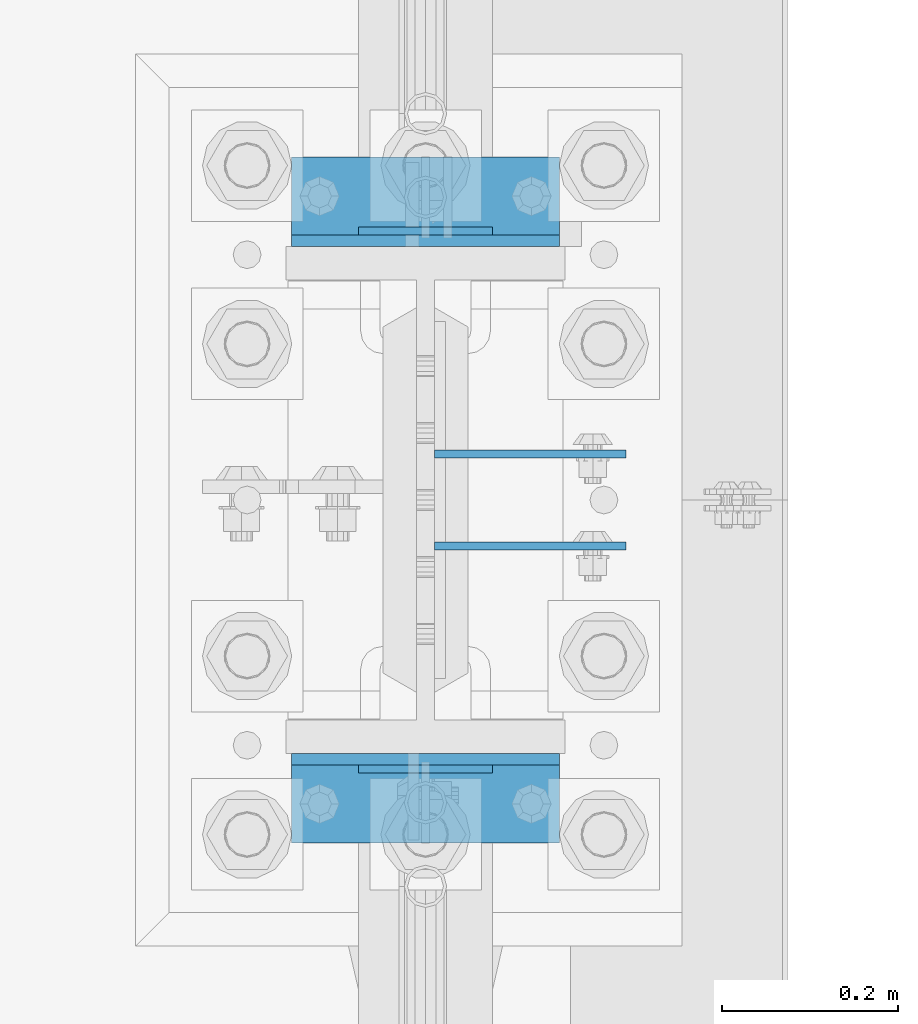
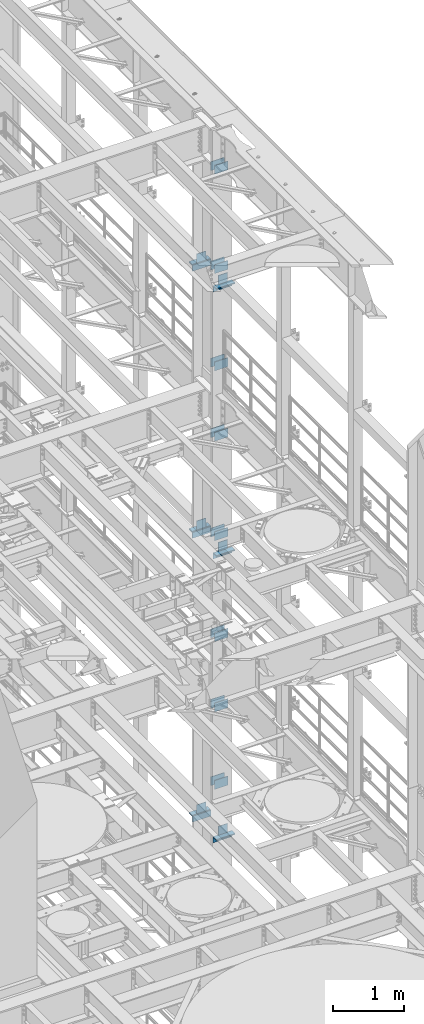
# One storey, part 1338 of 1876: 34 beams, 8 elements without a shape of their own.
"""IFC2X3 building model written with IfcOpenShell, lengths in millimetres."""

from ifc_helpers import new_model, si_unit, frame, origin_with_axes, place, context, subcontext, project, spatial, faceted_brep, material, type_object, element, aggregate, save


model = new_model("IFC2X3")

# Units and contexts
model_context = context("Model", 3, precision=1e-05, world=origin_with_axes())
body_context = subcontext(model_context, "Body", "Model", "MODEL_VIEW")
ifc_project = project(units=[si_unit("LENGTHUNIT", "METRE", prefix="MILLI"), si_unit("AREAUNIT", "SQUARE_METRE"), si_unit("VOLUMEUNIT", "CUBIC_METRE"), si_unit("MASSUNIT", "GRAM", prefix="KILO"), si_unit("TIMEUNIT", "SECOND"), si_unit("PLANEANGLEUNIT", "RADIAN"), si_unit("SOLIDANGLEUNIT", "STERADIAN"), si_unit("THERMODYNAMICTEMPERATUREUNIT", "DEGREE_CELSIUS"), si_unit("LUMINOUSINTENSITYUNIT", "LUMEN")], contexts=[model_context])

# Site, building, storey
site_placement = place(None, origin_with_axes())
site = spatial("IfcSite", under=ifc_project, at=site_placement, CompositionType="ELEMENT")
building_placement = place(site_placement, origin_with_axes())
building = spatial("IfcBuilding", under=site, at=building_placement, Name="Undefined", CompositionType="ELEMENT")
storey_placement = place(building_placement, origin_with_axes())
storey = spatial("IfcBuildingStorey", under=building, at=storey_placement, Name="Undefined", CompositionType="ELEMENT", Elevation=0.0)

# Assembly, beams
assembly_1_placement = place(storey_placement, origin_with_axes())
assembly_1 = element("IfcElementAssembly", 1, at=assembly_1_placement, inside=storey, Name="COLUMN", AssemblyPlace="NOTDEFINED", PredefinedType="RIGID_FRAME")
ifc_material = material(Name="STEEL/A36")
beam_type_1 = type_object("IfcBeamType", PredefinedType="NOTDEFINED")
beam_1_placement = place(assembly_1_placement, frame((7630.31875, 7672.38750076294, 21678.9), z_axis=(0.0, 0.0, -1.0), x_axis=(1.0, 0.0, 0.0)))
beam_1 = element("IfcBeam", 2, at=beam_1_placement, type_object=beam_type_1, material=ifc_material, Name="PLATE", context=body_context, shape_type="Brep", body=[
    faceted_brep([(0.0, 4.76249999999982, -76.1999999999998), (3.63797880709171e-12, 4.76249999999982, 76.1999969482422), (218.28125, 4.76250000000005, 76.2000000000007), (218.28125, 4.76250000000005, -76.2000000000007), (3.63797880709171e-12, -4.76249999999982, 76.1999969482422), (218.28125, -4.76250000000005, 76.2000000000007), (0.0, -4.76249999999982, -76.1999999999998), (218.28125, -4.76250000000005, -76.2000000000007)], [[[0, 1, 2, 3]], [[1, 4, 5, 2]], [[4, 6, 7, 5]], [[6, 0, 3, 7]], [[5, 7, 3, 2]], [[6, 4, 1, 0]]]),
])
beam_2_placement = place(assembly_1_placement, frame((7630.31875, 7567.61250076294, 21678.9), z_axis=(0.0, 0.0, -1.0), x_axis=(1.0, 0.0, 0.0)))
beam_2 = element("IfcBeam", 3, at=beam_2_placement, type_object=beam_type_1, material=ifc_material, Name="PLATE", context=body_context, shape_type="Brep", body=[
    faceted_brep([(0.0, 4.76249999999982, -76.1999999999998), (3.63797880709171e-12, 4.76249999999982, 76.1999969482422), (218.28125, 4.76250000000005, 76.2000000000007), (218.28125, 4.76250000000005, -76.2000000000007), (3.63797880709171e-12, -4.76249999999982, 76.1999969482422), (218.28125, -4.76250000000005, 76.2000000000007), (0.0, -4.76249999999982, -76.1999999999998), (218.28125, -4.76250000000005, -76.2000000000007)], [[[0, 1, 2, 3]], [[1, 4, 5, 2]], [[4, 6, 7, 5]], [[6, 0, 3, 7]], [[5, 7, 3, 2]], [[6, 4, 1, 0]]]),
])
beam_3_placement = place(assembly_1_placement, frame((7630.31875, 7672.38750076294, 19958.05), z_axis=(0.0, 0.0, -1.0), x_axis=(1.0, 0.0, 0.0)))
beam_3 = element("IfcBeam", 4, at=beam_3_placement, type_object=beam_type_1, material=ifc_material, Name="PLATE", context=body_context, shape_type="Brep", body=[
    faceted_brep([(0.0, 4.76249999999982, -76.1999999999998), (3.63797880709171e-12, 4.76249999999982, 76.1999969482422), (218.28125, 4.76250000000005, 76.2000000000007), (218.28125, 4.76250000000005, -76.2000000000007), (3.63797880709171e-12, -4.76249999999982, 76.1999969482422), (218.28125, -4.76250000000005, 76.2000000000007), (0.0, -4.76249999999982, -76.1999999999998), (218.28125, -4.76250000000005, -76.2000000000007)], [[[0, 1, 2, 3]], [[1, 4, 5, 2]], [[4, 6, 7, 5]], [[6, 0, 3, 7]], [[5, 7, 3, 2]], [[6, 4, 1, 0]]]),
])
beam_4_placement = place(assembly_1_placement, frame((7630.31875, 7567.61250076294, 19958.05), z_axis=(0.0, 0.0, -1.0), x_axis=(1.0, 0.0, 0.0)))
beam_4 = element("IfcBeam", 5, at=beam_4_placement, type_object=beam_type_1, material=ifc_material, Name="PLATE", context=body_context, shape_type="Brep", body=[
    faceted_brep([(0.0, 4.76249999999982, -76.1999999999998), (3.63797880709171e-12, 4.76249999999982, 76.1999969482422), (218.28125, 4.76250000000005, 76.2000000000007), (218.28125, 4.76250000000005, -76.2000000000007), (3.63797880709171e-12, -4.76249999999982, 76.1999969482422), (218.28125, -4.76250000000005, 76.2000000000007), (0.0, -4.76249999999982, -76.1999999999998), (218.28125, -4.76250000000005, -76.2000000000007)], [[[0, 1, 2, 3]], [[1, 4, 5, 2]], [[4, 6, 7, 5]], [[6, 0, 3, 7]], [[5, 7, 3, 2]], [[6, 4, 1, 0]]]),
])
beam_5_placement = place(assembly_1_placement, frame((7630.31875, 7672.38750076294, 18275.3), z_axis=(0.0, 0.0, -1.0), x_axis=(1.0, 0.0, 0.0)))
beam_5 = element("IfcBeam", 6, at=beam_5_placement, type_object=beam_type_1, material=ifc_material, Name="PLATE", context=body_context, shape_type="Brep", body=[
    faceted_brep([(0.0, 4.76249999999982, -76.1999999999998), (3.63797880709171e-12, 4.76249999999982, 76.1999969482422), (218.28125, 4.76250000000005, 76.2000000000007), (218.28125, 4.76250000000005, -76.2000000000007), (3.63797880709171e-12, -4.76249999999982, 76.1999969482422), (218.28125, -4.76250000000005, 76.2000000000007), (0.0, -4.76249999999982, -76.1999999999998), (218.28125, -4.76250000000005, -76.2000000000007)], [[[0, 1, 2, 3]], [[1, 4, 5, 2]], [[4, 6, 7, 5]], [[6, 0, 3, 7]], [[5, 7, 3, 2]], [[6, 4, 1, 0]]]),
])
beam_6_placement = place(assembly_1_placement, frame((7630.31875, 7567.61250076294, 18275.3), z_axis=(0.0, 0.0, -1.0), x_axis=(1.0, 0.0, 0.0)))
beam_6 = element("IfcBeam", 7, at=beam_6_placement, type_object=beam_type_1, material=ifc_material, Name="PLATE", context=body_context, shape_type="Brep", body=[
    faceted_brep([(0.0, 4.76249999999982, -76.1999999999998), (3.63797880709171e-12, 4.76249999999982, 76.1999969482422), (218.28125, 4.76250000000005, 76.2000000000007), (218.28125, 4.76250000000005, -76.2000000000007), (3.63797880709171e-12, -4.76249999999982, 76.1999969482422), (218.28125, -4.76250000000005, 76.2000000000007), (0.0, -4.76249999999982, -76.1999999999998), (218.28125, -4.76250000000005, -76.2000000000007)], [[[0, 1, 2, 3]], [[1, 4, 5, 2]], [[4, 6, 7, 5]], [[6, 0, 3, 7]], [[5, 7, 3, 2]], [[6, 4, 1, 0]]]),
])
beam_7_placement = place(assembly_1_placement, frame((7630.31875, 7672.38750076294, 17056.1), z_axis=(0.0, 0.0, -1.0), x_axis=(1.0, 0.0, 0.0)))
beam_7 = element("IfcBeam", 8, at=beam_7_placement, type_object=beam_type_1, material=ifc_material, Name="PLATE", context=body_context, shape_type="Brep", body=[
    faceted_brep([(0.0, 4.76249999999982, -76.1999999999998), (3.63797880709171e-12, 4.76249999999982, 76.1999969482422), (218.28125, 4.76250000000005, 76.2000000000007), (218.28125, 4.76250000000005, -76.2000000000007), (3.63797880709171e-12, -4.76249999999982, 76.1999969482422), (218.28125, -4.76250000000005, 76.2000000000007), (0.0, -4.76249999999982, -76.1999999999998), (218.28125, -4.76250000000005, -76.2000000000007)], [[[0, 1, 2, 3]], [[1, 4, 5, 2]], [[4, 6, 7, 5]], [[6, 0, 3, 7]], [[5, 7, 3, 2]], [[6, 4, 1, 0]]]),
])
beam_8_placement = place(assembly_1_placement, frame((7630.31875, 7567.61250076294, 17056.1), z_axis=(0.0, 0.0, -1.0), x_axis=(1.0, 0.0, 0.0)))
beam_8 = element("IfcBeam", 9, at=beam_8_placement, type_object=beam_type_1, material=ifc_material, Name="PLATE", context=body_context, shape_type="Brep", body=[
    faceted_brep([(0.0, 4.76249999999982, -76.1999999999998), (3.63797880709171e-12, 4.76249999999982, 76.1999969482422), (218.28125, 4.76250000000005, 76.2000000000007), (218.28125, 4.76250000000005, -76.2000000000007), (3.63797880709171e-12, -4.76249999999982, 76.1999969482422), (218.28125, -4.76250000000005, 76.2000000000007), (0.0, -4.76249999999982, -76.1999999999998), (218.28125, -4.76250000000005, -76.2000000000007)], [[[0, 1, 2, 3]], [[1, 4, 5, 2]], [[4, 6, 7, 5]], [[6, 0, 3, 7]], [[5, 7, 3, 2]], [[6, 4, 1, 0]]]),
])
beam_9_placement = place(assembly_1_placement, frame((7630.31875, 7672.38750076294, 15335.25), z_axis=(0.0, 0.0, -1.0), x_axis=(1.0, 0.0, 0.0)))
beam_9 = element("IfcBeam", 10, at=beam_9_placement, type_object=beam_type_1, material=ifc_material, Name="PLATE", context=body_context, shape_type="Brep", body=[
    faceted_brep([(0.0, 4.76249999999982, -76.1999999999998), (3.63797880709171e-12, 4.76249999999982, 76.1999969482422), (218.28125, 4.76250000000005, 76.2000000000007), (218.28125, 4.76250000000005, -76.2000000000007), (3.63797880709171e-12, -4.76249999999982, 76.1999969482422), (218.28125, -4.76250000000005, 76.2000000000007), (0.0, -4.76249999999982, -76.1999999999998), (218.28125, -4.76250000000005, -76.2000000000007)], [[[0, 1, 2, 3]], [[1, 4, 5, 2]], [[4, 6, 7, 5]], [[6, 0, 3, 7]], [[5, 7, 3, 2]], [[6, 4, 1, 0]]]),
])
beam_10_placement = place(assembly_1_placement, frame((7630.31875, 7567.61250076294, 15335.25), z_axis=(0.0, 0.0, -1.0), x_axis=(1.0, 0.0, 0.0)))
beam_10 = element("IfcBeam", 11, at=beam_10_placement, type_object=beam_type_1, material=ifc_material, Name="PLATE", context=body_context, shape_type="Brep", body=[
    faceted_brep([(0.0, 4.76249999999982, -76.1999999999998), (3.63797880709171e-12, 4.76249999999982, 76.1999969482422), (218.28125, 4.76250000000005, 76.2000000000007), (218.28125, 4.76250000000005, -76.2000000000007), (3.63797880709171e-12, -4.76249999999982, 76.1999969482422), (218.28125, -4.76250000000005, 76.2000000000007), (0.0, -4.76249999999982, -76.1999999999998), (218.28125, -4.76250000000005, -76.2000000000007)], [[[0, 1, 2, 3]], [[1, 4, 5, 2]], [[4, 6, 7, 5]], [[6, 0, 3, 7]], [[5, 7, 3, 2]], [[6, 4, 1, 0]]]),
])

assembly_2_placement = place(storey_placement, origin_with_axes())
assembly_2 = element("IfcElementAssembly", 12, at=assembly_2_placement, inside=storey, Name="COLUMN", AssemblyPlace="NOTDEFINED", PredefinedType="RIGID_FRAME")
beam_11_placement = place(assembly_2_placement, frame((7630.31875, 7672.38750076294, 13589.0), z_axis=(0.0, 0.0, -1.0), x_axis=(1.0, 0.0, 0.0)))
beam_11 = element("IfcBeam", 13, at=beam_11_placement, type_object=beam_type_1, material=ifc_material, Name="PLATE", context=body_context, shape_type="Brep", body=[
    faceted_brep([(0.0, 4.76249999999982, -76.1999999999998), (3.63797880709171e-12, 4.76249999999982, 76.1999969482422), (218.28125, 4.76250000000005, 76.2000000000007), (218.28125, 4.76250000000005, -76.2000000000007), (3.63797880709171e-12, -4.76249999999982, 76.1999969482422), (218.28125, -4.76250000000005, 76.2000000000007), (0.0, -4.76249999999982, -76.1999999999998), (218.28125, -4.76250000000005, -76.2000000000007)], [[[0, 1, 2, 3]], [[1, 4, 5, 2]], [[4, 6, 7, 5]], [[6, 0, 3, 7]], [[5, 7, 3, 2]], [[6, 4, 1, 0]]]),
])
beam_12_placement = place(assembly_2_placement, frame((7630.31875, 7567.61250076294, 13589.0), z_axis=(0.0, 0.0, -1.0), x_axis=(1.0, 0.0, 0.0)))
beam_12 = element("IfcBeam", 14, at=beam_12_placement, type_object=beam_type_1, material=ifc_material, Name="PLATE", context=body_context, shape_type="Brep", body=[
    faceted_brep([(0.0, 4.76249999999982, -76.1999999999998), (3.63797880709171e-12, 4.76249999999982, 76.1999969482422), (218.28125, 4.76250000000005, 76.2000000000007), (218.28125, 4.76250000000005, -76.2000000000007), (3.63797880709171e-12, -4.76249999999982, 76.1999969482422), (218.28125, -4.76250000000005, 76.2000000000007), (0.0, -4.76249999999982, -76.1999999999998), (218.28125, -4.76250000000005, -76.2000000000007)], [[[0, 1, 2, 3]], [[1, 4, 5, 2]], [[4, 6, 7, 5]], [[6, 0, 3, 7]], [[5, 7, 3, 2]], [[6, 4, 1, 0]]]),
])
beam_13_placement = place(assembly_2_placement, frame((7630.31875, 7672.38750076294, 12369.8), z_axis=(0.0, 0.0, -1.0), x_axis=(1.0, 0.0, 0.0)))
beam_13 = element("IfcBeam", 15, at=beam_13_placement, type_object=beam_type_1, material=ifc_material, Name="PLATE", context=body_context, shape_type="Brep", body=[
    faceted_brep([(0.0, 4.76249999999982, -76.1999999999998), (3.63797880709171e-12, 4.76249999999982, 76.1999969482422), (218.28125, 4.76250000000005, 76.2000000000007), (218.28125, 4.76250000000005, -76.2000000000007), (3.63797880709171e-12, -4.76249999999982, 76.1999969482422), (218.28125, -4.76250000000005, 76.2000000000007), (0.0, -4.76249999999982, -76.1999999999998), (218.28125, -4.76250000000005, -76.2000000000007)], [[[0, 1, 2, 3]], [[1, 4, 5, 2]], [[4, 6, 7, 5]], [[6, 0, 3, 7]], [[5, 7, 3, 2]], [[6, 4, 1, 0]]]),
])
beam_14_placement = place(assembly_2_placement, frame((7630.31875, 7567.61250076294, 12369.8), z_axis=(0.0, 0.0, -1.0), x_axis=(1.0, 0.0, 0.0)))
beam_14 = element("IfcBeam", 16, at=beam_14_placement, type_object=beam_type_1, material=ifc_material, Name="PLATE", context=body_context, shape_type="Brep", body=[
    faceted_brep([(0.0, 4.76249999999982, -76.1999999999998), (3.63797880709171e-12, 4.76249999999982, 76.1999969482422), (218.28125, 4.76250000000005, 76.2000000000007), (218.28125, 4.76250000000005, -76.2000000000007), (3.63797880709171e-12, -4.76249999999982, 76.1999969482422), (218.28125, -4.76250000000005, 76.2000000000007), (0.0, -4.76249999999982, -76.1999999999998), (218.28125, -4.76250000000005, -76.2000000000007)], [[[0, 1, 2, 3]], [[1, 4, 5, 2]], [[4, 6, 7, 5]], [[6, 0, 3, 7]], [[5, 7, 3, 2]], [[6, 4, 1, 0]]]),
])
beam_15_placement = place(assembly_2_placement, frame((7630.31875, 7672.38750076294, 11029.95), z_axis=(0.0, 0.0, -1.0), x_axis=(1.0, 0.0, 0.0)))
beam_15 = element("IfcBeam", 17, at=beam_15_placement, type_object=beam_type_1, material=ifc_material, Name="PLATE", context=body_context, shape_type="Brep", body=[
    faceted_brep([(0.0, 4.76249999999982, -76.1999999999998), (3.63797880709171e-12, 4.76249999999982, 76.1999969482422), (218.28125, 4.76250000000005, 76.2000000000007), (218.28125, 4.76250000000005, -76.2000000000007), (3.63797880709171e-12, -4.76249999999982, 76.1999969482422), (218.28125, -4.76250000000005, 76.2000000000007), (0.0, -4.76249999999982, -76.1999999999998), (218.28125, -4.76250000000005, -76.2000000000007)], [[[0, 1, 2, 3]], [[1, 4, 5, 2]], [[4, 6, 7, 5]], [[6, 0, 3, 7]], [[5, 7, 3, 2]], [[6, 4, 1, 0]]]),
])
beam_16_placement = place(assembly_2_placement, frame((7630.31875, 7567.61250076294, 11029.95), z_axis=(0.0, 0.0, -1.0), x_axis=(1.0, 0.0, 0.0)))
beam_16 = element("IfcBeam", 18, at=beam_16_placement, type_object=beam_type_1, material=ifc_material, Name="PLATE", context=body_context, shape_type="Brep", body=[
    faceted_brep([(0.0, 4.76249999999982, -76.1999999999998), (3.63797880709171e-12, 4.76249999999982, 76.1999969482422), (218.28125, 4.76250000000005, 76.2000000000007), (218.28125, 4.76250000000005, -76.2000000000007), (3.63797880709171e-12, -4.76249999999982, 76.1999969482422), (218.28125, -4.76250000000005, 76.2000000000007), (0.0, -4.76249999999982, -76.1999999999998), (218.28125, -4.76250000000005, -76.2000000000007)], [[[0, 1, 2, 3]], [[1, 4, 5, 2]], [[4, 6, 7, 5]], [[6, 0, 3, 7]], [[5, 7, 3, 2]], [[6, 4, 1, 0]]]),
])

# Assembly, beam
assembly_3_placement = place(storey_placement, origin_with_axes())
assembly_3 = element("IfcElementAssembly", 19, at=assembly_3_placement, inside=storey, Name="BEAM", AssemblyPlace="NOTDEFINED", PredefinedType="RIGID_FRAME")
beam_17_placement = place(assembly_3_placement, frame((7696.2, 7926.3875, 19958.05), z_axis=(0.0, 0.0, 1.0), x_axis=(-1.0, 0.0, 0.0)))
beam_17 = element("IfcBeam", 20, at=beam_17_placement, type_object=beam_type_1, material=ifc_material, Name="PLATE", context=body_context, shape_type="Brep", body=[
    faceted_brep([(0.0, 4.76249999999982, -76.1999999999998), (3.63797880709171e-12, 4.76249999999982, 76.1999969482422), (152.399993896484, 4.76250000000073, 76.1999969482422), (152.4, 4.76249999999982, -76.1999999999998), (3.63797880709171e-12, -4.76249999999982, 76.1999969482422), (152.399993896484, -4.76250000000073, 76.1999969482422), (0.0, -4.76249999999982, -76.1999999999998), (152.4, -4.76249999999982, -76.1999999999998)], [[[0, 1, 2, 3]], [[4, 5, 2, 1]], [[4, 6, 7, 5]], [[6, 0, 3, 7]], [[5, 7, 3, 2]], [[6, 4, 1, 0]]]),
])

assembly_4_placement = place(storey_placement, origin_with_axes())
assembly_4 = element("IfcElementAssembly", 21, at=assembly_4_placement, inside=storey, Name="BEAM", AssemblyPlace="NOTDEFINED", PredefinedType="RIGID_FRAME")
beam_18_placement = place(assembly_4_placement, frame((7696.2, 7313.6125, 19958.05), z_axis=(0.0, 0.0, -1.0), x_axis=(-1.0, 0.0, 0.0)))
beam_18 = element("IfcBeam", 22, at=beam_18_placement, type_object=beam_type_1, material=ifc_material, Name="PLATE", context=body_context, shape_type="Brep", body=[
    faceted_brep([(0.0, 4.76249999999982, -76.1999999999998), (3.63797880709171e-12, 4.76249999999982, 76.1999969482422), (152.399993896484, 4.76250000000073, 76.1999969482422), (152.4, 4.76249999999982, -76.1999999999998), (3.63797880709171e-12, -4.76249999999982, 76.1999969482422), (152.399993896484, -4.76250000000073, 76.1999969482422), (0.0, -4.76249999999982, -76.1999999999998), (152.4, -4.76249999999982, -76.1999999999998)], [[[0, 1, 2, 3]], [[4, 5, 2, 1]], [[4, 6, 7, 5]], [[6, 0, 3, 7]], [[5, 7, 3, 2]], [[6, 4, 1, 0]]]),
])

assembly_5_placement = place(storey_placement, origin_with_axes())
assembly_5 = element("IfcElementAssembly", 23, at=assembly_5_placement, inside=storey, Name="BEAM", AssemblyPlace="NOTDEFINED", PredefinedType="RIGID_FRAME")
beam_19_placement = place(assembly_5_placement, frame((7696.2, 7926.3875, 15335.25), z_axis=(0.0, 0.0, 1.0), x_axis=(-1.0, 0.0, 0.0)))
beam_19 = element("IfcBeam", 24, at=beam_19_placement, type_object=beam_type_1, material=ifc_material, Name="PLATE", context=body_context, shape_type="Brep", body=[
    faceted_brep([(0.0, 4.76249999999982, -76.1999999999998), (3.63797880709171e-12, 4.76249999999982, 76.1999969482422), (152.399993896484, 4.76250000000073, 76.1999969482422), (152.4, 4.76249999999982, -76.1999999999998), (3.63797880709171e-12, -4.76249999999982, 76.1999969482422), (152.399993896484, -4.76250000000073, 76.1999969482422), (0.0, -4.76249999999982, -76.1999999999998), (152.4, -4.76249999999982, -76.1999999999998)], [[[0, 1, 2, 3]], [[4, 5, 2, 1]], [[4, 6, 7, 5]], [[6, 0, 3, 7]], [[5, 7, 3, 2]], [[6, 4, 1, 0]]]),
])

assembly_6_placement = place(storey_placement, origin_with_axes())
assembly_6 = element("IfcElementAssembly", 25, at=assembly_6_placement, inside=storey, Name="BEAM", AssemblyPlace="NOTDEFINED", PredefinedType="RIGID_FRAME")
beam_20_placement = place(assembly_6_placement, frame((7696.2, 7313.6125, 15335.25), z_axis=(0.0, 0.0, -1.0), x_axis=(-1.0, 0.0, 0.0)))
beam_20 = element("IfcBeam", 26, at=beam_20_placement, type_object=beam_type_1, material=ifc_material, Name="PLATE", context=body_context, shape_type="Brep", body=[
    faceted_brep([(0.0, 4.76249999999982, -76.1999999999998), (3.63797880709171e-12, 4.76249999999982, 76.1999969482422), (152.399993896484, 4.76250000000073, 76.1999969482422), (152.4, 4.76249999999982, -76.1999999999998), (3.63797880709171e-12, -4.76249999999982, 76.1999969482422), (152.399993896484, -4.76250000000073, 76.1999969482422), (0.0, -4.76249999999982, -76.1999999999998), (152.4, -4.76249999999982, -76.1999999999998)], [[[0, 1, 2, 3]], [[4, 5, 2, 1]], [[4, 6, 7, 5]], [[6, 0, 3, 7]], [[5, 7, 3, 2]], [[6, 4, 1, 0]]]),
])

assembly_7_placement = place(storey_placement, origin_with_axes())
assembly_7 = element("IfcElementAssembly", 27, at=assembly_7_placement, inside=storey, Name="BEAM", AssemblyPlace="NOTDEFINED", PredefinedType="RIGID_FRAME")
beam_21_placement = place(assembly_7_placement, frame((7696.2, 7926.3875, 10420.35), z_axis=(0.0, 0.0, 1.0), x_axis=(-1.0, 0.0, 0.0)))
beam_21 = element("IfcBeam", 28, at=beam_21_placement, type_object=beam_type_1, material=ifc_material, Name="PLATE", context=body_context, shape_type="Brep", body=[
    faceted_brep([(0.0, 4.76249999999982, -76.1999999999998), (3.63797880709171e-12, 4.76249999999982, 76.1999969482422), (152.399993896484, 4.76250000000073, 76.1999969482422), (152.4, 4.76249999999982, -76.1999999999998), (3.63797880709171e-12, -4.76249999999982, 76.1999969482422), (152.399993896484, -4.76250000000073, 76.1999969482422), (0.0, -4.76249999999982, -76.1999999999998), (152.4, -4.76249999999982, -76.1999999999998)], [[[0, 1, 2, 3]], [[4, 5, 2, 1]], [[4, 6, 7, 5]], [[6, 0, 3, 7]], [[5, 7, 3, 2]], [[6, 4, 1, 0]]]),
])

assembly_8_placement = place(storey_placement, origin_with_axes())
assembly_8 = element("IfcElementAssembly", 29, at=assembly_8_placement, inside=storey, Name="BEAM", AssemblyPlace="NOTDEFINED", PredefinedType="RIGID_FRAME")
beam_22_placement = place(assembly_8_placement, frame((7696.2, 7313.6125, 10420.35), z_axis=(0.0, 0.0, -1.0), x_axis=(-1.0, 0.0, 0.0)))
beam_22 = element("IfcBeam", 30, at=beam_22_placement, type_object=beam_type_1, material=ifc_material, Name="PLATE", context=body_context, shape_type="Brep", body=[
    faceted_brep([(0.0, 4.76249999999982, -76.1999999999998), (3.63797880709171e-12, 4.76249999999982, 76.1999969482422), (152.399993896484, 4.76250000000073, 76.1999969482422), (152.4, 4.76249999999982, -76.1999999999998), (3.63797880709171e-12, -4.76249999999982, 76.1999969482422), (152.399993896484, -4.76250000000073, 76.1999969482422), (0.0, -4.76249999999982, -76.1999999999998), (152.4, -4.76249999999982, -76.1999999999998)], [[[0, 1, 2, 3]], [[4, 5, 2, 1]], [[4, 6, 7, 5]], [[6, 0, 3, 7]], [[5, 7, 3, 2]], [[6, 4, 1, 0]]]),
])

# Beam
beam_type_2 = type_object("IfcBeamType", PredefinedType="NOTDEFINED")
beam_23_placement = place(assembly_3_placement, frame((7467.6, 7966.075, 19877.0875), z_axis=(0.0, 1.0, 0.0), x_axis=(1.0, 0.0, 0.0)))
beam_23 = element("IfcBeam", 31, at=beam_23_placement, type_object=beam_type_2, material=ifc_material, Name="PLATE", context=body_context, shape_type="Brep", body=[
    faceted_brep([(0.0, 4.76250000000073, -44.4499999999998), (0.0, 4.76250000000073, 44.4499999999998), (304.799999999999, 4.76250000000073, 44.4499999999998), (304.799999999999, 4.76250000000073, -44.4499999999998), (0.0, -4.76250000000073, 44.4499999999998), (304.799999999999, -4.76250000000073, 44.4499999999998), (0.0, -4.76250000000073, -44.4499999999998), (304.799999999999, -4.76250000000073, -44.4499999999998)], [[[0, 1, 2, 3]], [[1, 4, 5, 2]], [[4, 6, 7, 5]], [[6, 0, 3, 7]], [[5, 7, 3, 2]], [[6, 4, 1, 0]]]),
])

aggregate(assembly_3, [beam_17, beam_23])

beam_24_placement = place(assembly_4_placement, frame((7467.6, 7273.925, 19877.0875), z_axis=(0.0, -1.0, 0.0), x_axis=(1.0, 0.0, 0.0)))
beam_24 = element("IfcBeam", 32, at=beam_24_placement, type_object=beam_type_2, material=ifc_material, Name="PLATE", context=body_context, shape_type="Brep", body=[
    faceted_brep([(0.0, 4.76250000000073, -44.4499999999998), (0.0, 4.76250000000073, 44.4499999999998), (304.799999999999, 4.76250000000073, 44.4499999999998), (304.799999999999, 4.76250000000073, -44.4499999999998), (0.0, -4.76250000000073, 44.4499999999998), (304.799999999999, -4.76250000000073, 44.4499999999998), (0.0, -4.76250000000073, -44.4499999999998), (304.799999999999, -4.76250000000073, -44.4499999999998)], [[[0, 1, 2, 3]], [[1, 4, 5, 2]], [[4, 6, 7, 5]], [[6, 0, 3, 7]], [[5, 7, 3, 2]], [[6, 4, 1, 0]]]),
])

aggregate(assembly_4, [beam_18, beam_24])

beam_25_placement = place(assembly_5_placement, frame((7467.6, 7966.075, 15254.2875), z_axis=(0.0, 1.0, 0.0), x_axis=(1.0, 0.0, 0.0)))
beam_25 = element("IfcBeam", 33, at=beam_25_placement, type_object=beam_type_2, material=ifc_material, Name="PLATE", context=body_context, shape_type="Brep", body=[
    faceted_brep([(0.0, 4.76250000000073, -44.4499999999998), (0.0, 4.76250000000073, 44.4499999999998), (304.799999999999, 4.76250000000073, 44.4499999999998), (304.799999999999, 4.76250000000073, -44.4499999999998), (0.0, -4.76250000000073, 44.4499999999998), (304.799999999999, -4.76250000000073, 44.4499999999998), (0.0, -4.76250000000073, -44.4499999999998), (304.799999999999, -4.76250000000073, -44.4499999999998)], [[[0, 1, 2, 3]], [[1, 4, 5, 2]], [[4, 6, 7, 5]], [[6, 0, 3, 7]], [[5, 7, 3, 2]], [[6, 4, 1, 0]]]),
])

aggregate(assembly_5, [beam_19, beam_25])

beam_26_placement = place(assembly_6_placement, frame((7467.6, 7273.925, 15254.2875), z_axis=(0.0, -1.0, 0.0), x_axis=(1.0, 0.0, 0.0)))
beam_26 = element("IfcBeam", 34, at=beam_26_placement, type_object=beam_type_2, material=ifc_material, Name="PLATE", context=body_context, shape_type="Brep", body=[
    faceted_brep([(0.0, 4.76250000000073, -44.4499999999998), (0.0, 4.76250000000073, 44.4499999999998), (304.799999999999, 4.76250000000073, 44.4499999999998), (304.799999999999, 4.76250000000073, -44.4499999999998), (0.0, -4.76250000000073, 44.4499999999998), (304.799999999999, -4.76250000000073, 44.4499999999998), (0.0, -4.76250000000073, -44.4499999999998), (304.799999999999, -4.76250000000073, -44.4499999999998)], [[[0, 1, 2, 3]], [[1, 4, 5, 2]], [[4, 6, 7, 5]], [[6, 0, 3, 7]], [[5, 7, 3, 2]], [[6, 4, 1, 0]]]),
])

aggregate(assembly_6, [beam_20, beam_26])

beam_27_placement = place(assembly_7_placement, frame((7467.6, 7966.075, 10339.3875), z_axis=(0.0, 1.0, 0.0), x_axis=(1.0, 0.0, 0.0)))
beam_27 = element("IfcBeam", 35, at=beam_27_placement, type_object=beam_type_2, material=ifc_material, Name="PLATE", context=body_context, shape_type="Brep", body=[
    faceted_brep([(0.0, 4.76250000000073, -44.4499999999998), (0.0, 4.76250000000073, 44.4499999999998), (304.799999999999, 4.76250000000073, 44.4499999999998), (304.799999999999, 4.76250000000073, -44.4499999999998), (0.0, -4.76250000000073, 44.4499999999998), (304.799999999999, -4.76250000000073, 44.4499999999998), (0.0, -4.76250000000073, -44.4499999999998), (304.799999999999, -4.76250000000073, -44.4499999999998)], [[[0, 1, 2, 3]], [[1, 4, 5, 2]], [[4, 6, 7, 5]], [[6, 0, 3, 7]], [[5, 7, 3, 2]], [[6, 4, 1, 0]]]),
])

aggregate(assembly_7, [beam_21, beam_27])

beam_28_placement = place(assembly_8_placement, frame((7467.6, 7273.925, 10339.3875), z_axis=(0.0, -1.0, 0.0), x_axis=(1.0, 0.0, 0.0)))
beam_28 = element("IfcBeam", 36, at=beam_28_placement, type_object=beam_type_2, material=ifc_material, Name="PLATE", context=body_context, shape_type="Brep", body=[
    faceted_brep([(0.0, 4.76250000000073, -44.4499999999998), (0.0, 4.76250000000073, 44.4499999999998), (304.799999999999, 4.76250000000073, 44.4499999999998), (304.799999999999, 4.76250000000073, -44.4499999999998), (0.0, -4.76250000000073, 44.4499999999998), (304.799999999999, -4.76250000000073, 44.4499999999998), (0.0, -4.76250000000073, -44.4499999999998), (304.799999999999, -4.76250000000073, -44.4499999999998)], [[[0, 1, 2, 3]], [[1, 4, 5, 2]], [[4, 6, 7, 5]], [[6, 0, 3, 7]], [[5, 7, 3, 2]], [[6, 4, 1, 0]]]),
])

aggregate(assembly_8, [beam_22, beam_28])

beam_type_3 = type_object("IfcBeamType", Name="L4X4X3/8", PredefinedType="NOTDEFINED")
beam_29_placement = place(assembly_1_placement, frame((7772.4, 7959.725, 19821.525), z_axis=(0.0, 1.0, 0.0), x_axis=(-1.0, 0.0, 0.0)))
beam_29 = element("IfcBeam", 37, at=beam_29_placement, type_object=beam_type_3, material=ifc_material, Name="ANGLE", ObjectType="L4X4X3/8", context=body_context, shape_type="Brep", body=[
    faceted_brep([(0.0, 50.7999999999993, -50.8000000000002), (0.0, 50.7999999999993, 50.8000000000002), (304.799999999999, 50.7999999999993, 50.8000000000002), (304.799999999999, 50.7999999999993, -50.8000000000002), (0.0, 41.2750000000015, 50.8000000000002), (304.799999999999, 41.2750000000015, 50.8000000000002), (0.0, 41.2750000000015, -41.2749999999996), (304.799999999999, 41.2750000000015, -41.2749999999996), (0.0, -50.7999999999993, -41.2749999999996), (304.799999999999, -50.7999999999993, -41.2749999999996), (0.0, -50.7999999999993, -50.8000000000002), (304.799999999999, -50.7999999999993, -50.8000000000002)], [[[0, 1, 2, 3]], [[1, 4, 5, 2]], [[4, 6, 7, 5]], [[6, 8, 9, 7]], [[8, 10, 11, 9]], [[10, 0, 3, 11]], [[5, 7, 9, 11, 3, 2]], [[10, 8, 6, 4, 1, 0]]]),
])

beam_30_placement = place(assembly_1_placement, frame((7467.6, 7280.275, 19821.525), z_axis=(0.0, -1.0, 0.0), x_axis=(1.0, 0.0, 0.0)))
beam_30 = element("IfcBeam", 38, at=beam_30_placement, type_object=beam_type_3, material=ifc_material, Name="ANGLE", ObjectType="L4X4X3/8", context=body_context, shape_type="Brep", body=[
    faceted_brep([(0.0, 50.7999999999993, -50.8000000000002), (0.0, 50.7999999999993, 50.8000000000002), (304.799999999999, 50.7999999999993, 50.8000000000002), (304.799999999999, 50.7999999999993, -50.8000000000002), (0.0, 41.2750000000015, 50.8000000000002), (304.799999999999, 41.2750000000015, 50.8000000000002), (0.0, 41.2750000000015, -41.2749999999996), (304.799999999999, 41.2750000000015, -41.2749999999996), (0.0, -50.7999999999993, -41.2749999999996), (304.799999999999, -50.7999999999993, -41.2749999999996), (0.0, -50.7999999999993, -50.8000000000002), (304.799999999999, -50.7999999999993, -50.8000000000002)], [[[0, 1, 2, 3]], [[1, 4, 5, 2]], [[4, 6, 7, 5]], [[6, 8, 9, 7]], [[8, 10, 11, 9]], [[10, 0, 3, 11]], [[5, 7, 9, 11, 3, 2]], [[10, 8, 6, 4, 1, 0]]]),
])

beam_31_placement = place(assembly_1_placement, frame((7772.4, 7959.725, 15198.725), z_axis=(0.0, 1.0, 0.0), x_axis=(-1.0, 0.0, 0.0)))
beam_31 = element("IfcBeam", 39, at=beam_31_placement, type_object=beam_type_3, material=ifc_material, Name="ANGLE", ObjectType="L4X4X3/8", context=body_context, shape_type="Brep", body=[
    faceted_brep([(0.0, 50.7999999999993, -50.8000000000002), (0.0, 50.7999999999993, 50.8000000000002), (304.799999999999, 50.7999999999993, 50.8000000000002), (304.799999999999, 50.7999999999993, -50.8000000000002), (0.0, 41.2750000000015, 50.8000000000002), (304.799999999999, 41.2750000000015, 50.8000000000002), (0.0, 41.2750000000015, -41.2749999999996), (304.799999999999, 41.2750000000015, -41.2749999999996), (0.0, -50.7999999999993, -41.2749999999996), (304.799999999999, -50.7999999999993, -41.2749999999996), (0.0, -50.7999999999993, -50.8000000000002), (304.799999999999, -50.7999999999993, -50.8000000000002)], [[[0, 1, 2, 3]], [[1, 4, 5, 2]], [[4, 6, 7, 5]], [[6, 8, 9, 7]], [[8, 10, 11, 9]], [[10, 0, 3, 11]], [[5, 7, 9, 11, 3, 2]], [[10, 8, 6, 4, 1, 0]]]),
])

beam_32_placement = place(assembly_1_placement, frame((7467.6, 7280.275, 15198.725), z_axis=(0.0, -1.0, 0.0), x_axis=(1.0, 0.0, 0.0)))
beam_32 = element("IfcBeam", 40, at=beam_32_placement, type_object=beam_type_3, material=ifc_material, Name="ANGLE", ObjectType="L4X4X3/8", context=body_context, shape_type="Brep", body=[
    faceted_brep([(0.0, 50.7999999999993, -50.8000000000002), (0.0, 50.7999999999993, 50.8000000000002), (304.799999999999, 50.7999999999993, 50.8000000000002), (304.799999999999, 50.7999999999993, -50.8000000000002), (0.0, 41.2750000000015, 50.8000000000002), (304.799999999999, 41.2750000000015, 50.8000000000002), (0.0, 41.2750000000015, -41.2749999999996), (304.799999999999, 41.2750000000015, -41.2749999999996), (0.0, -50.7999999999993, -41.2749999999996), (304.799999999999, -50.7999999999993, -41.2749999999996), (0.0, -50.7999999999993, -50.8000000000002), (304.799999999999, -50.7999999999993, -50.8000000000002)], [[[0, 1, 2, 3]], [[1, 4, 5, 2]], [[4, 6, 7, 5]], [[6, 8, 9, 7]], [[8, 10, 11, 9]], [[10, 0, 3, 11]], [[5, 7, 9, 11, 3, 2]], [[10, 8, 6, 4, 1, 0]]]),
])

aggregate(assembly_1, [beam_1, beam_2, beam_3, beam_4, beam_5, beam_6, beam_7, beam_8, beam_9, beam_10, beam_29, beam_30, beam_31, beam_32])

beam_33_placement = place(assembly_2_placement, frame((7772.4, 7959.725, 10283.825), z_axis=(0.0, 1.0, 0.0), x_axis=(-1.0, 0.0, 0.0)))
beam_33 = element("IfcBeam", 41, at=beam_33_placement, type_object=beam_type_3, material=ifc_material, Name="ANGLE", ObjectType="L4X4X3/8", context=body_context, shape_type="Brep", body=[
    faceted_brep([(0.0, 50.7999999999993, -50.8000000000002), (0.0, 50.7999999999993, 50.8000000000002), (304.799999999999, 50.7999999999993, 50.8000000000002), (304.799999999999, 50.7999999999993, -50.8000000000002), (0.0, 41.2750000000015, 50.8000000000002), (304.799999999999, 41.2750000000015, 50.8000000000002), (0.0, 41.2750000000015, -41.2749999999996), (304.799999999999, 41.2750000000015, -41.2749999999996), (0.0, -50.7999999999993, -41.2749999999996), (304.799999999999, -50.7999999999993, -41.2749999999996), (0.0, -50.7999999999993, -50.8000000000002), (304.799999999999, -50.7999999999993, -50.8000000000002)], [[[0, 1, 2, 3]], [[1, 4, 5, 2]], [[4, 6, 7, 5]], [[6, 8, 9, 7]], [[8, 10, 11, 9]], [[10, 0, 3, 11]], [[5, 7, 9, 11, 3, 2]], [[10, 8, 6, 4, 1, 0]]]),
])

beam_34_placement = place(assembly_2_placement, frame((7467.6, 7280.275, 10283.825), z_axis=(0.0, -1.0, 0.0), x_axis=(1.0, 0.0, 0.0)))
beam_34 = element("IfcBeam", 42, at=beam_34_placement, type_object=beam_type_3, material=ifc_material, Name="ANGLE", ObjectType="L4X4X3/8", context=body_context, shape_type="Brep", body=[
    faceted_brep([(0.0, 50.7999999999993, -50.8000000000002), (0.0, 50.7999999999993, 50.8000000000002), (304.799999999999, 50.7999999999993, 50.8000000000002), (304.799999999999, 50.7999999999993, -50.8000000000002), (0.0, 41.2750000000015, 50.8000000000002), (304.799999999999, 41.2750000000015, 50.8000000000002), (0.0, 41.2750000000015, -41.2749999999996), (304.799999999999, 41.2750000000015, -41.2749999999996), (0.0, -50.7999999999993, -41.2749999999996), (304.799999999999, -50.7999999999993, -41.2749999999996), (0.0, -50.7999999999993, -50.8000000000002), (304.799999999999, -50.7999999999993, -50.8000000000002)], [[[0, 1, 2, 3]], [[1, 4, 5, 2]], [[4, 6, 7, 5]], [[6, 8, 9, 7]], [[8, 10, 11, 9]], [[10, 0, 3, 11]], [[5, 7, 9, 11, 3, 2]], [[10, 8, 6, 4, 1, 0]]]),
])

aggregate(assembly_2, [beam_11, beam_12, beam_13, beam_14, beam_15, beam_16, beam_33, beam_34])

save(model, "model.ifc")
